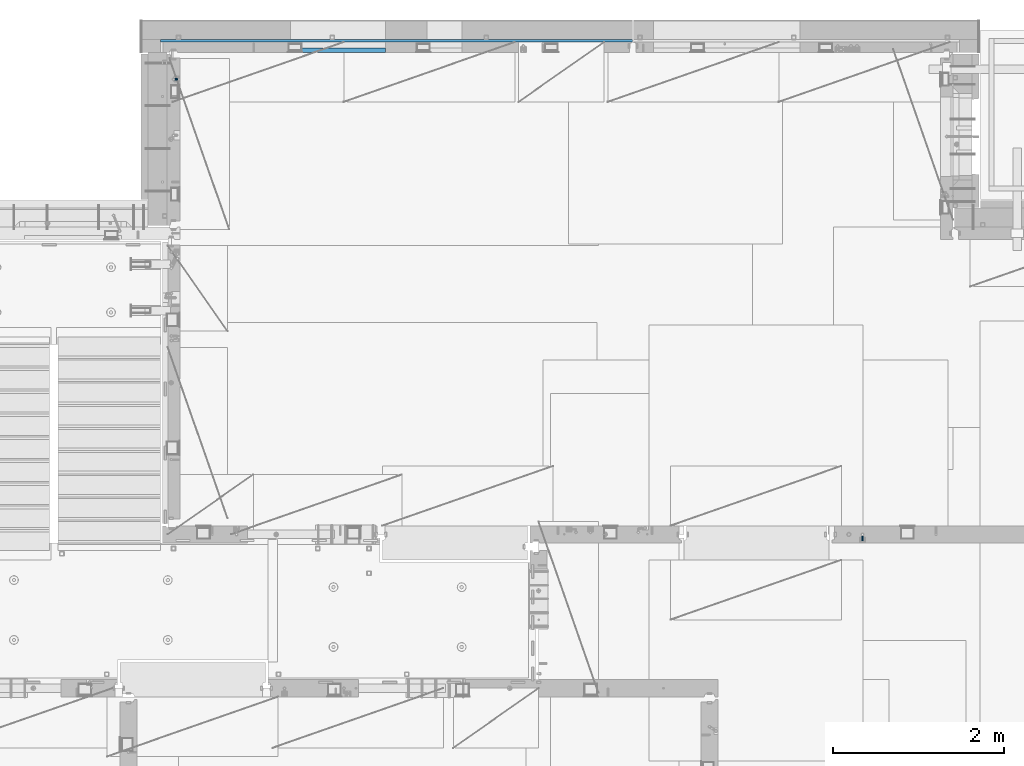
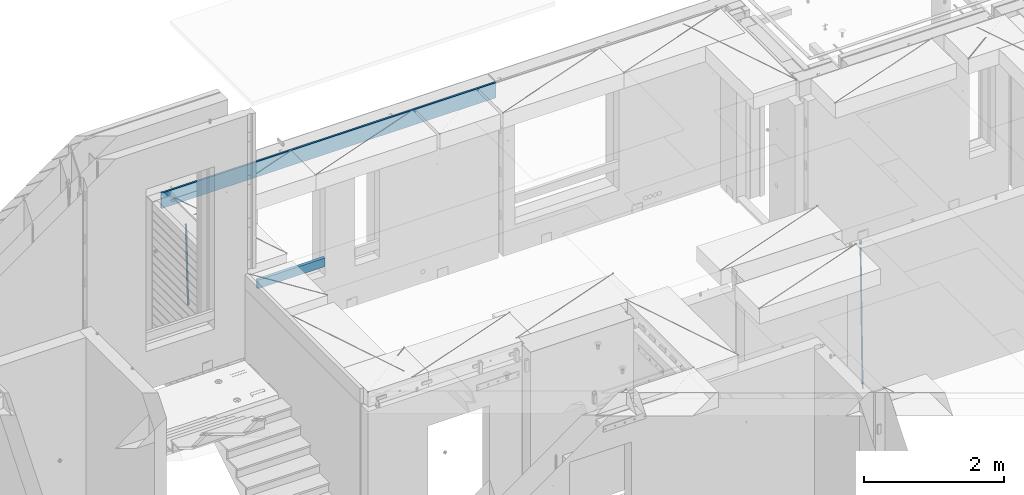
# One storey, part 125 of 352: 4 beams, 3 elements without a shape of their own.
"""IFC2X3 building model written with IfcOpenShell, lengths in millimetres."""

from ifc_helpers import new_model, si_unit, frame, origin_with_axes, place, context, subcontext, project, spatial, faceted_brep, material, type_object, element, aggregate, save


model = new_model("IFC2X3")

# Units and contexts
model_context = context("Model", 3, precision=1e-05, world=origin_with_axes())
body_context = subcontext(model_context, "Body", "Model", "MODEL_VIEW")
ifc_project = project(units=[si_unit("LENGTHUNIT", "METRE", prefix="MILLI"), si_unit("AREAUNIT", "SQUARE_METRE"), si_unit("VOLUMEUNIT", "CUBIC_METRE"), si_unit("MASSUNIT", "GRAM", prefix="KILO"), si_unit("TIMEUNIT", "SECOND"), si_unit("PLANEANGLEUNIT", "RADIAN"), si_unit("SOLIDANGLEUNIT", "STERADIAN"), si_unit("THERMODYNAMICTEMPERATUREUNIT", "DEGREE_CELSIUS"), si_unit("LUMINOUSINTENSITYUNIT", "LUMEN")], contexts=[model_context])

# Site, building, storey
site_placement = place(None, origin_with_axes())
site = spatial("IfcSite", under=ifc_project, at=site_placement, CompositionType="ELEMENT")
building_placement = place(site_placement, origin_with_axes())
building = spatial("IfcBuilding", under=site, at=building_placement, CompositionType="ELEMENT")
storey_placement = place(building_placement, origin_with_axes())
storey = spatial("IfcBuildingStorey", under=building, at=storey_placement, Name="6", CompositionType="ELEMENT", Elevation=0.0)

# Assembly, beam
assembly_1_placement = place(storey_placement, origin_with_axes())
assembly_1 = element("IfcElementAssembly", 1, at=assembly_1_placement, inside=storey, AssemblyPlace="NOTDEFINED", PredefinedType="REINFORCEMENT_UNIT")
ifc_material_1 = material()
beam_type_1 = type_object("IfcBeamType", Name="D20", PredefinedType="NOTDEFINED")
beam_1_placement = place(assembly_1_placement, frame((30400.0000000039, 16915.0002418615, 96990.0), z_axis=(-0.000205762999925498, 0.999642804629538, -0.0267249099901004), x_axis=(4.30000201928125e-08, 0.0267249099948059, 0.999642825806181)))
beam_1 = element("IfcBeam", 2, at=beam_1_placement, type_object=beam_type_1, material=ifc_material_1, Name="JM20", ObjectType="D20", context=body_context, shape_type="Brep", body=[
    faceted_brep([(0.0, -10.0, 0.0), (-4.19531716033816e-08, -7.07106781186667, -7.07106781187031), (60.4266690400545, -7.0710677960451, -7.07106780570757), (60.4266690441291, -9.99999998418934, 6.15546014159918e-09), (0.0, 0.0, -10.0), (60.426669036824, 1.58106558956206e-08, -9.99999999384454), (4.196772351861e-08, 7.07106781186303, -7.07106781186667), (60.4266690363438, 7.07106782768096, -7.07106780570757), (0.0, 10.0, 0.0), (60.4266690388904, 10.0000000158179, 6.15182216279209e-09), (4.196772351861e-08, 7.07106781185939, 7.07106781185939), (60.4266690429649, 7.07106782768096, 7.07106781802577), (0.0, 0.0, 10.0), (60.4266690461809, 1.58179318532348e-08, 10.0000000061555), (-4.19531716033816e-08, -7.07106781187031, 7.07106781185939), (60.4266690466611, -7.07106779605238, 7.07106781802213), (61.0378400410118, -7.07106779588503, -7.07106780564936), (60.991799419251, -9.99999998403655, 6.21366780251265e-09), (61.0569027789461, 1.5985278878361e-08, -9.99999999378269), (61.0378209396877, 7.07106782784831, -7.07106780564936), (60.9917724058905, 10.0000000159635, 6.21366780251265e-09), (60.9457317841297, 7.07106782781193, 7.0710678180767), (60.9266690461809, 1.59488990902901e-08, 10.0000000062028), (60.9457508854539, -7.07106779591413, 7.0710678180767), (61.6489592143771, -7.07106614513759, -7.06310863441468), (61.5568818710308, -9.9999984576425, 0.00735959856683621), (61.6870830769039, 1.71821739058942e-06, -9.99179257185824), (61.6489210170112, 7.07106947854481, -7.06310888312146), (61.556827851804, 10.0000015422847, 0.00735924683976918), (61.4647505084577, 7.07106922979438, 7.07782747982128), (61.4266266459163, 1.36643211590126e-06, 10.0065114172685), (61.464788705809, -7.07106639389531, 7.07782772852806), (176.543135720174, -7.07075579406956, -5.56673531796696), (176.451058376813, -9.99968810657447, 1.50373291501455), (176.581259582701, 0.000312069292704109, -8.49541925541052), (176.543097522794, 7.07137982961285, -5.56673556667374), (176.451004357587, 10.00031189336, 1.50373256329476), (176.35892701424, 7.07137958085514, 8.57420079627263), (176.320803151699, 0.000311717507429421, 11.5028847337162), (176.358965211621, -7.07075604281999, 8.57420104497578), (177.098753836006, -7.07075429323595, -5.55949898843028), (176.98362511232, -9.99968666800123, 1.510669025065), (177.146421932586, 0.000313595905026887, -8.48805862247536), (177.098706077581, 7.07138133041735, -5.55949936166144), (176.983557571715, 10.0003133318824, 1.51066849724157), (176.868428848029, 7.07138095712435, 8.58083651073321), (176.820760751449, 0.000313067976094317, 11.5093961447819), (176.868476606425, -7.07075466652896, 8.58083688396073), (177.654312950661, -7.07075204110879, -5.54863964998367), (177.516135294456, -9.99968450931192, 1.52107783331303), (177.711524267797, 0.000315886711177882, -8.47701274570863), (177.654255632195, 7.07138358250813, -5.54864021007961), (177.516054233929, 10.0003154905207, 1.5210770412159), (177.377876577739, 7.0713830223176, 8.59079452451624), (177.320665260588, 0.000315094497636892, 11.5191676202448), (177.377933896176, -7.07075260129932, 8.59079508461218), (299.499456785634, -7.07025810522464, -3.16697112782276), (299.361279129444, -9.99919057342777, 3.90274635547394), (299.556668102785, 0.000809822595329024, -6.09534422354773), (299.499399467197, 7.07187751838501, -3.1669716879187), (299.361198068917, 10.0008094264049, 3.90274556338045), (299.223020412712, 7.07187695819448, 10.9724630466735), (299.165809095575, 0.000809030381788034, 13.9008361423985), (299.223077731163, -7.07025866542244, 10.9724636067695), (300.03174732349, -7.07025594743027, -3.15656661289177), (299.971788958996, -9.99918809853989, 3.91467979818117), (300.056572611924, 0.000811849109595641, -6.08557274808481), (300.031722507032, 7.07187967631762, -3.15656653768019), (299.971753863239, 10.0008119014747, 3.91467990454839), (299.91179549876, 7.07187975035777, 10.9859263156177), (299.886970210311, 0.000811953817901667, 13.9149324508144), (299.911820315203, -7.0702558733974, 10.9859262404061), (300.564137759997, -7.07025623699155, -3.15794273276697), (300.582413367199, -9.99918843065097, 3.91310145956595), (300.556570941641, 0.000811577163403854, -6.0868651410201), (300.564145451674, 7.07187938674906, -3.15794274158179), (300.582424244858, 10.0008115693345, 3.91310144710224), (300.600699852032, 7.07187937566778, 10.9841456394352), (300.608266670402, 0.000811561512819026, 13.9130680476919), (300.600692160384, -7.07025624805829, 10.98414564825), (2294.16589219622, -7.0713405251372, -8.31099358700158), (2294.1841678034, -10.0002727187966, -1.23994939466866), (2294.15832537785, -0.000272710982244462, -11.2399159952547), (2294.16589988787, 7.07079509858886, -8.31099359582004), (2294.18417868105, 9.99972728118883, -1.23994940713601), (2294.20245428824, 7.07079508752213, 5.83109478519327), (2294.2100211066, -0.00027272663282929, 8.76001719345368), (2294.20244659658, -7.07134053620393, 5.83109479401173), (2294.7782683276, -7.07134085819416, -8.31257645345977), (2294.72126025338, -10.000273010919, -1.24133766827799), (2294.84007459224, -0.000273081772320438, -11.2416781768807), (2294.87047377572, 7.07079471537872, -8.31281477453012), (2294.85165844864, 9.9997269181622, -1.24167470516841), (2294.7946503744, 7.07079476544459, 5.82956408001337), (2294.73284410976, -0.000273010977252852, 8.75866580342336), (2294.7024449263, -7.07134080815013, 5.82980240107645), (2295.39054023061, -7.0793250091956, -8.30442771922026), (2295.25826128852, -10.0072756143927, -1.23419071494573), (2295.52170777075, -0.00916171800054144, -11.2326063125765), (2295.57492774284, 7.06160849139269, -8.30343918807193), (2295.51902460904, 9.99102432676591, -1.23279272078435), (2295.38674566693, 7.06307372157607, 5.83744428349019), (2295.25557812679, -0.0070895696117077, 8.76562287684646), (2295.20235815471, -7.07785977901949, 5.83645575234186), (2317.1947101649, -7.36365585014573, -8.01423575520312), (2317.06243122277, -10.2916064553428, -0.94399875092131), (2317.32587770502, -0.293492558957951, -10.9424143485521), (2317.37909767711, 6.77727765044983, -8.01324722405116), (2317.32319454331, 9.70669348581578, -0.942600756767206), (2317.1909156012, 6.77874288063322, 6.12763624751096), (2317.05974806109, -0.291420410569117, 9.0558148408636), (2317.00652808898, -7.36219061996962, 6.12664771636264), (2317.83015404257, -7.37194216843636, -8.00577862486898), (2317.72252095213, -10.300214160583, -0.935213608652703), (2317.90419832576, -0.301033978277701, -10.9347174723516), (2317.90127966482, 6.77046829039318, -8.00629749759901), (2317.82310777172, 9.70017451494641, -0.935947405505431), (2317.71547468127, 6.77190252279979, 6.13461761071085), (2317.64143039809, -0.29900566735887, 9.06355645819713), (2317.64434905903, -7.37050793602975, 6.13513648344451), (2318.46565174212, -7.3700661537805, -7.99751648408346), (2318.38266643914, -10.2982456018653, -0.926623872735945), (2318.48256818345, -0.299336209594912, -10.9272153854981), (2318.42350634121, 6.77200652527245, -7.99954269419686), (2318.32306384158, 9.70166538090416, -0.929489366557391), (2318.2400785386, 6.77348593281204, 6.14140324480104), (2318.22316209726, -0.297244011366274, 9.07110214621207), (2318.2822239395, -7.36858674623363, 6.1434294549108), (2418.48643733139, -7.07180401323421, -6.70013846199799), (2418.4034520284, -9.99998346132634, 0.370754149349523), (2418.5033537727, -0.00107406904135132, -9.62983736341266), (2418.44429193046, 7.07026866581873, -6.70216467211139), (2418.34384943081, 9.99992752145772, 0.367888655531715), (2418.26086412782, 7.0717480733656, 7.43878126688651), (2418.24394768651, 0.00101812917273492, 10.3684801682975), (2418.30300952874, -7.07032460568735, 7.44080747699627)], [[[0, 1, 2, 3]], [[1, 4, 5, 2]], [[4, 6, 7, 5]], [[6, 8, 9, 7]], [[8, 10, 11, 9]], [[10, 12, 13, 11]], [[12, 14, 15, 13]], [[14, 0, 3, 15]], [[14, 12, 10, 8, 6, 4, 1, 0]], [[3, 2, 16, 17]], [[2, 5, 18, 16]], [[5, 7, 19, 18]], [[7, 9, 20, 19]], [[9, 11, 21, 20]], [[11, 13, 22, 21]], [[13, 15, 23, 22]], [[15, 3, 17, 23]], [[17, 16, 24, 25]], [[16, 18, 26, 24]], [[18, 19, 27, 26]], [[19, 20, 28, 27]], [[20, 21, 29, 28]], [[21, 22, 30, 29]], [[22, 23, 31, 30]], [[23, 17, 25, 31]], [[25, 24, 32, 33]], [[24, 26, 34, 32]], [[26, 27, 35, 34]], [[27, 28, 36, 35]], [[28, 29, 37, 36]], [[29, 30, 38, 37]], [[30, 31, 39, 38]], [[31, 25, 33, 39]], [[33, 32, 40, 41]], [[32, 34, 42, 40]], [[34, 35, 43, 42]], [[35, 36, 44, 43]], [[36, 37, 45, 44]], [[37, 38, 46, 45]], [[38, 39, 47, 46]], [[39, 33, 41, 47]], [[41, 40, 48, 49]], [[40, 42, 50, 48]], [[42, 43, 51, 50]], [[43, 44, 52, 51]], [[44, 45, 53, 52]], [[45, 46, 54, 53]], [[46, 47, 55, 54]], [[47, 41, 49, 55]], [[49, 48, 56, 57]], [[48, 50, 58, 56]], [[50, 51, 59, 58]], [[51, 52, 60, 59]], [[52, 53, 61, 60]], [[53, 54, 62, 61]], [[54, 55, 63, 62]], [[55, 49, 57, 63]], [[57, 56, 64, 65]], [[56, 58, 66, 64]], [[58, 59, 67, 66]], [[59, 60, 68, 67]], [[60, 61, 69, 68]], [[61, 62, 70, 69]], [[62, 63, 71, 70]], [[63, 57, 65, 71]], [[65, 64, 72, 73]], [[64, 66, 74, 72]], [[66, 67, 75, 74]], [[67, 68, 76, 75]], [[68, 69, 77, 76]], [[69, 70, 78, 77]], [[70, 71, 79, 78]], [[71, 65, 73, 79]], [[73, 72, 80, 81]], [[72, 74, 82, 80]], [[74, 75, 83, 82]], [[75, 76, 84, 83]], [[76, 77, 85, 84]], [[77, 78, 86, 85]], [[78, 79, 87, 86]], [[79, 73, 81, 87]], [[81, 80, 88, 89]], [[80, 82, 90, 88]], [[82, 83, 91, 90]], [[83, 84, 92, 91]], [[84, 85, 93, 92]], [[85, 86, 94, 93]], [[86, 87, 95, 94]], [[87, 81, 89, 95]], [[89, 88, 96, 97]], [[88, 90, 98, 96]], [[90, 91, 99, 98]], [[91, 92, 100, 99]], [[92, 93, 101, 100]], [[93, 94, 102, 101]], [[94, 95, 103, 102]], [[95, 89, 97, 103]], [[97, 96, 104, 105]], [[96, 98, 106, 104]], [[98, 99, 107, 106]], [[99, 100, 108, 107]], [[100, 101, 109, 108]], [[101, 102, 110, 109]], [[102, 103, 111, 110]], [[103, 97, 105, 111]], [[105, 104, 112, 113]], [[104, 106, 114, 112]], [[106, 107, 115, 114]], [[107, 108, 116, 115]], [[108, 109, 117, 116]], [[109, 110, 118, 117]], [[110, 111, 119, 118]], [[111, 105, 113, 119]], [[113, 112, 120, 121]], [[112, 114, 122, 120]], [[114, 115, 123, 122]], [[115, 116, 124, 123]], [[116, 117, 125, 124]], [[117, 118, 126, 125]], [[118, 119, 127, 126]], [[119, 113, 121, 127]], [[121, 120, 128, 129]], [[120, 122, 130, 128]], [[122, 123, 131, 130]], [[123, 124, 132, 131]], [[124, 125, 133, 132]], [[125, 126, 134, 133]], [[126, 127, 135, 134]], [[127, 121, 129, 135]], [[130, 131, 132, 133, 134, 135, 129, 128]]]),
])
aggregate(assembly_1, [beam_1])

assembly_2_placement = place(storey_placement, origin_with_axes())
assembly_2 = element("IfcElementAssembly", 3, at=assembly_2_placement, inside=storey, AssemblyPlace="NOTDEFINED", PredefinedType="REINFORCEMENT_UNIT")
beam_type_2 = type_object("IfcBeamType", Name="D25", PredefinedType="NOTDEFINED")
beam_2_placement = place(assembly_2_placement, frame((22375.0000022791, 22307.0000022831, 97990.0), z_axis=(-0.999642804636942, -0.000205726999925762, -0.0267249099902983), x_axis=(-0.0267249099948371, 4.30000201934385e-08, 0.999642825806181)))
beam_2 = element("IfcBeam", 4, at=beam_2_placement, type_object=beam_type_2, material=ifc_material_1, Name="JM25", ObjectType="D25", context=body_context, shape_type="Brep", body=[
    faceted_brep([(-7.41420080885291e-08, -12.5, -3.63797880709171e-12), (-6.42030499875546e-08, -10.8253175473074, -6.25000000000364), (60.4103898235917, -10.8253175318459, -6.2499999938409), (60.4103898269532, -12.4999999845422, 6.16273609921336e-09), (-3.70782800018787e-08, -6.25000000000364, -10.8253175473074), (60.4103898202884, -6.24999998454587, -10.8253175411446), (-1.45519152283669e-11, -3.63797880709171e-12, -12.5), (60.4103898179019, 1.54577719513327e-08, -12.4999999938373), (3.70637280866504e-08, 6.25, -10.8253175473074), (60.410389817087, 6.25000001545777, -10.825317541141), (6.42030499875546e-08, 10.8253175473001, -6.25000000000364), (60.410389818062, 10.8253175627578, -6.24999999383726), (7.41420080885291e-08, 12.4999999999927, 0.0), (60.4103898205503, 12.5000000154541, 6.16273609921336e-09), (6.42176019027829e-08, 10.8253175473001, 6.24999999999636), (60.4103898238973, 10.8253175627651, 6.2500000061591), (3.70928319171071e-08, 6.24999999999636, 10.8253175473037), (60.4103898272151, 6.25000001546141, 10.8253175534664), (1.45519152283669e-11, -3.63797880709171e-12, 12.4999999999964), (60.4103898296162, 1.54541339725256e-08, 12.5000000061591), (-3.7049176171422e-08, -6.25000000000364, 10.8253175473001), (60.4103898304165, -6.24999998454587, 10.8253175534701), (-6.41884980723262e-08, -10.8253175473074, 6.25), (60.4103898294561, -10.8253175318459, 6.25000000616637), (61.0324985728803, -10.8253175316895, -6.24999999377542), (60.991802792938, -12.4999999843931, 6.22458173893392e-09), (61.0622854283865, -6.24999998437852, -10.8253175410755), (61.0731819955545, 1.5628756955266e-08, -12.4999999937718), (61.0622685480339, 6.25000001562512, -10.8253175410791), (61.032469335245, 10.8253175629216, -6.24999999377178), (60.9917690322181, 12.5000000156033, 6.22458173893392e-09), (60.9510732522613, 10.8253175629034, 6.25000000621731), (60.9212863967696, 6.25000001558874, 10.8253175535247), (60.9103898296162, 1.55814632307738e-08, 12.5000000062137), (60.9213032771368, -6.24999998441126, 10.8253175535174), (60.9511024898966, -10.8253175317113, 6.25000000621731), (61.6545545670233, -10.8253158516927, -6.24189838219536), (61.573166454793, -12.499998414296, 0.00757164385504439), (61.7141257553885, -6.24999822394238, -10.8168280205282), (61.7359179680789, 1.80548886419274e-06, -12.491368569139), (61.7140919992817, 6.25000177601396, -10.8168282403167), (61.6544960997562, 10.8253192428383, -6.2418987628771), (61.5730989426083, 12.5000015856094, 0.0075712042817031), (61.4917108303925, 10.8253190230062, 6.25704123032847), (61.4321396420273, 6.25000139525582, 10.8319708686649), (61.4103474293224, 1.36582457344048e-06, 12.5065114172721), (61.4321733981196, -6.24999860470052, 10.8319710884571), (61.4917692976451, -10.8253160715249, 6.25704161101385), (176.524302641745, -10.8250056210964, -4.74584321979273), (176.442914529529, -12.4996881836996, 1.50362680625403), (176.583873830095, -6.24968799334965, -9.3207728581292), (176.605666042786, 0.000312036081595579, -10.9953134067364), (176.583840074018, 6.25031200660669, -9.32077307791769), (176.524244174492, 10.8256294734347, -4.74584360047811), (176.44284701733, 12.5003118162058, 1.50362636668069), (176.361458905099, 10.8256292535989, 7.75309639272746), (176.301887716749, 6.25031162585219, 12.3280260310676), (176.280095504058, 0.000311596420942806, 14.0025665796711), (176.301921472827, -6.24968837410415, 12.3280262508561), (176.361517372367, -10.8250058409321, 7.75309677341284), (177.085397012124, -10.8250041057399, -4.73853556792164), (176.983633547483, -12.4996867233749, 1.51066909103247), (177.159881729676, -6.24968643771717, -9.31327097355097), (177.187129580227, 0.000313606451527448, -10.987740468332), (177.159839524218, 6.25031356221734, -9.31327130338468), (177.085323910098, 10.8256309887511, -4.73853613920801), (176.983549136537, 12.5003132764905, 1.51066843136869), (176.881785671867, 10.8256306588555, 7.7598730903228), (176.80730095433, 6.25031299082912, 12.3346084959521), (176.780053103794, 0.000312946667690994, 14.0090779907332), (176.807343159802, -6.2496870091054, 12.3346088257895), (176.881858773908, -10.8250044356355, 7.7598736616128), (177.646431799818, -10.8250018318176, -4.72756919822132), (177.524295146417, -12.4996845320202, 1.52123723245313), (177.735828462886, -6.24968410334986, -9.30201312475765), (177.768531371941, 0.00031596292683389, -10.9763759912421), (177.735777808921, 6.25031589654827, -9.30201361973741), (177.646344064575, 10.8256332626152, -4.72757005553649), (177.524193838486, 12.5003154677688, 1.52123624250817), (177.402057185071, 10.8256327675663, 7.77004267317898), (177.312660521988, 6.2503150390985, 12.3444865997226), (177.279957612933, 0.00031497282179771, 14.0188494661961), (177.312711175953, -6.24968496079964, 12.3444870946951), (177.402144920314, -10.8250023268702, 7.77004353049415), (299.450416306776, -10.8245081491878, -2.34670520440704), (299.32827965336, -12.4991908493976, 3.9021012262674), (299.539812969844, -6.24919042071997, -6.92114913095065), (299.572515878914, 0.000809645553090377, -8.59551199742418), (299.539762315893, 6.25080957917817, -6.9211496259195), (299.450328571547, 10.8261269452451, -2.34670606172585), (299.328178345429, 12.5008091504023, 3.9021002363188), (299.206041692043, 10.8261264501925, 10.1509066669969), (299.11664502896, 6.25080872172475, 14.7253505935405), (299.083942119891, 0.000808655455330154, 16.3997134600104), (299.116695682911, -6.24919127817338, 14.7253510885093), (299.206129427272, -10.8245086442366, 10.1509075243121), (300.022114107283, -10.8245058320463, -2.33553040816332), (299.97179243555, -12.4991882411778, 3.91467976726199), (300.058946494231, -6.24918831662217, -6.9110017919993), (300.072420388053, 0.000811671710835071, -8.58574052196127), (300.058925469799, 6.25081168339239, -6.91100170781283), (300.022077691901, 10.8261292625939, -2.33553026234586), (299.971750386685, 12.5008117588586, 3.91467993563856), (299.921428714966, 10.8261293497235, 10.1648901110639), (299.884596327989, 6.25081183430666, 14.7403614948998), (299.871122434168, 0.000811845966381952, 16.4151002248582), (299.884617352436, -6.24918816571881, 14.7403614107134), (299.921465130334, -10.8245057449167, 10.1648899652428), (300.593917726728, -10.8245062259339, -2.33749813354007), (300.615424329342, -12.4991886845492, 3.91246486206001), (300.578176108116, -6.24918867429733, -6.91278859651356), (300.572417427509, 0.00081132728519151, -8.58746114217138), (300.578184718717, 6.25081132569903, -6.91278861431056), (300.59393264071, 10.8261288686736, -2.33749816436102), (300.615441550515, 12.5008113154472, 3.91246482646966), (300.636948153115, 10.8261288568356, 10.1624278220661), (300.652689771727, 6.25081130520266, 14.7377182850432), (300.658448452334, 0.000811303612863412, 16.4123908306974), (300.65268116114, -6.24918869479734, 14.7377183028366), (300.636933239148, -10.8245062377719, 10.162427852887), (1293.8225958722, -10.8251904135213, -5.7554570479515), (1293.84410247482, -12.4998728721366, 0.494505947652215), (1293.80685425361, -6.2498728618848, -10.330747510925), (1293.801095573, 0.000127139694086509, -12.0054200565755), (1293.80686286419, 6.25012713810793, -10.3307475287183), (1293.82261078618, 10.8254446810788, -5.75545707877609), (1293.84411969599, 12.5001271278561, 0.49450591205823), (1293.86562629859, 10.8254446692445, 6.7444689076583), (1293.8813679172, 6.25012711760428, 11.3197593706318), (1293.88712659782, 0.00012711602539639, 12.994431916286), (1293.88135930662, -6.24987288238844, 11.3197593884252), (1293.86561138462, -10.8251904253593, 6.7444689384829), (1294.43576264779, -10.8251908359052, -5.75756711474241), (1294.39401066334, -12.4998732509448, 0.492613570157118), (1294.4881651176, -6.24987333120953, -10.3330920792978), (1294.53717687333, 0.000126632643514313, -12.0079531043048), (1294.56966525462, 6.25012661264918, -10.3333725306838), (1294.5769250259, 10.8254441614699, -5.75805287079493), (1294.55701093735, 12.5001266367835, 0.492052667374082), (1294.51525895292, 10.825444221744, 6.74223335227362), (1294.46285648308, 6.25012671704826, 11.3177583168253), (1294.41384472734, 0.000126753191580065, 12.9926193418323), (1294.38135634607, -6.24987322681045, 11.318038768215), (1294.37409657479, -10.8251907756348, 6.74271910832613), (1295.04882664244, -10.8331853159034, -5.74940783883358), (1294.94382667454, -12.5070429642874, 0.499931077909423), (1295.16936177819, -6.25875627512141, -10.3240260249331), (1295.27313478947, -0.00947040924438625, -11.9981582317523), (1295.33233978174, 6.24018118068125, -10.3232220864411), (1295.33111282514, 10.8156093981706, -5.74801537651729), (1295.26978268167, 12.4908319473179, 0.501538954897114), (1295.16478271378, 10.8169742989339, 6.75087787164011), (1295.04424757806, 6.24254525814467, 11.3254960577397), (1294.94047456676, -0.00674060772507801, 12.9996282645552), (1294.88126957447, -6.25639219765071, 11.3246921192476), (1294.88249653111, -10.8318204151437, 6.74948540932019), (1316.80386422646, -11.116875459662, -5.45986978806832), (1316.69886425855, -12.790733108046, 0.789469128674682), (1316.92439936219, -6.54244641887635, -10.0344879741715), (1317.02817237348, -0.293160553006601, -11.7086201809871), (1317.08737736575, 5.95649103692267, -10.0336840356795), (1317.08615040916, 10.5319192544084, -5.45847732575203), (1317.02482026568, 12.2071418035557, 0.791077005658735), (1316.91982029779, 10.5332841551717, 7.0404159223981), (1316.79928516207, 5.9588551143861, 11.6150341085013), (1316.69551215076, -0.290430751483655, 13.2891663153168), (1316.63630715849, -6.54008234141656, 11.6142301700129), (1316.6375341151, -11.1155105589023, 7.03902346008545), (1317.48953548315, -11.1258167532178, -5.45074418126023), (1317.39899812841, -12.7998629970425, 0.798787218573125), (1317.57265877169, -6.55089985429368, -10.0258602820722), (1317.62609517592, -0.300957588759047, -11.7006624193855), (1317.63552645453, 5.94934306058713, -10.0263887130131), (1317.59842550401, 10.5252390823007, -5.4516594505003), (1317.52473349411, 12.2006228327155, 0.79773035668768), (1317.43419613934, 10.5265765888907, 7.0472617565174), (1317.35107285083, 5.95165968996662, 11.6223778573367), (1317.2976364466, -0.29828257556801, 13.2971799946463), (1317.28820516799, -6.54858322491418, 11.6229062882776), (1317.32530611851, -11.1244792466277, 7.04817702575747), (1318.17526469367, -11.1237887330935, -5.44182040245869), (1318.09919107273, -12.797775016028, 0.807903115066438), (1318.22097315147, -6.5489957269856, -10.0174341323618), (1318.22406890181, -0.299208089221793, -11.6929060708244), (1318.18372244084, 5.95094862978294, -10.0192948650074), (1318.11074457024, 10.526749984605, -5.44504328594121), (1318.02468965146, 12.2021136975018, 0.804181649778911), (1317.94861603052, 10.52812741456, 7.05390516730768), (1317.90290757272, 5.95333440845207, 11.6295188972072), (1317.8998118224, -0.296453229308099, 13.3049908356734), (1317.94015828335, -6.54660994831283, 11.6313796298491), (1318.01313615397, -11.1224113031385, 7.0571280507902), (1418.17602640855, -10.8255863639497, -4.14470589025586), (1418.09995278763, -12.4995726468842, 2.10501762727654), (1418.22173486637, -6.25079335783812, -8.72031962014808), (1418.2248306167, -0.00100572007431765, -10.3957915586216), (1418.18448415573, 6.24915099893042, -8.72218035279366), (1418.11150628512, 10.8249523537488, -4.14792877373111), (1418.02545136634, 12.500316066642, 2.10129616199265), (1417.94937774542, 10.8263297837075, 8.35101967951414), (1417.90366928761, 6.2515367775959, 12.9266334094173), (1417.90057353729, 0.00174913983573788, 14.6021053478798), (1417.94091999825, -6.248407579169, 12.9284941420592), (1418.01389786886, -10.824208933991, 8.35424256299666)], [[[0, 1, 2, 3]], [[1, 4, 5, 2]], [[4, 6, 7, 5]], [[6, 8, 9, 7]], [[8, 10, 11, 9]], [[10, 12, 13, 11]], [[12, 14, 15, 13]], [[14, 16, 17, 15]], [[16, 18, 19, 17]], [[18, 20, 21, 19]], [[20, 22, 23, 21]], [[22, 0, 3, 23]], [[22, 20, 18, 16, 14, 12, 10, 8, 6, 4, 1, 0]], [[3, 2, 24, 25]], [[2, 5, 26, 24]], [[5, 7, 27, 26]], [[7, 9, 28, 27]], [[9, 11, 29, 28]], [[11, 13, 30, 29]], [[13, 15, 31, 30]], [[15, 17, 32, 31]], [[17, 19, 33, 32]], [[19, 21, 34, 33]], [[21, 23, 35, 34]], [[23, 3, 25, 35]], [[25, 24, 36, 37]], [[24, 26, 38, 36]], [[26, 27, 39, 38]], [[27, 28, 40, 39]], [[28, 29, 41, 40]], [[29, 30, 42, 41]], [[30, 31, 43, 42]], [[31, 32, 44, 43]], [[32, 33, 45, 44]], [[33, 34, 46, 45]], [[34, 35, 47, 46]], [[35, 25, 37, 47]], [[37, 36, 48, 49]], [[36, 38, 50, 48]], [[38, 39, 51, 50]], [[39, 40, 52, 51]], [[40, 41, 53, 52]], [[41, 42, 54, 53]], [[42, 43, 55, 54]], [[43, 44, 56, 55]], [[44, 45, 57, 56]], [[45, 46, 58, 57]], [[46, 47, 59, 58]], [[47, 37, 49, 59]], [[49, 48, 60, 61]], [[48, 50, 62, 60]], [[50, 51, 63, 62]], [[51, 52, 64, 63]], [[52, 53, 65, 64]], [[53, 54, 66, 65]], [[54, 55, 67, 66]], [[55, 56, 68, 67]], [[56, 57, 69, 68]], [[57, 58, 70, 69]], [[58, 59, 71, 70]], [[59, 49, 61, 71]], [[61, 60, 72, 73]], [[60, 62, 74, 72]], [[62, 63, 75, 74]], [[63, 64, 76, 75]], [[64, 65, 77, 76]], [[65, 66, 78, 77]], [[66, 67, 79, 78]], [[67, 68, 80, 79]], [[68, 69, 81, 80]], [[69, 70, 82, 81]], [[70, 71, 83, 82]], [[71, 61, 73, 83]], [[73, 72, 84, 85]], [[72, 74, 86, 84]], [[74, 75, 87, 86]], [[75, 76, 88, 87]], [[76, 77, 89, 88]], [[77, 78, 90, 89]], [[78, 79, 91, 90]], [[79, 80, 92, 91]], [[80, 81, 93, 92]], [[81, 82, 94, 93]], [[82, 83, 95, 94]], [[83, 73, 85, 95]], [[85, 84, 96, 97]], [[84, 86, 98, 96]], [[86, 87, 99, 98]], [[87, 88, 100, 99]], [[88, 89, 101, 100]], [[89, 90, 102, 101]], [[90, 91, 103, 102]], [[91, 92, 104, 103]], [[92, 93, 105, 104]], [[93, 94, 106, 105]], [[94, 95, 107, 106]], [[95, 85, 97, 107]], [[97, 96, 108, 109]], [[96, 98, 110, 108]], [[98, 99, 111, 110]], [[99, 100, 112, 111]], [[100, 101, 113, 112]], [[101, 102, 114, 113]], [[102, 103, 115, 114]], [[103, 104, 116, 115]], [[104, 105, 117, 116]], [[105, 106, 118, 117]], [[106, 107, 119, 118]], [[107, 97, 109, 119]], [[109, 108, 120, 121]], [[108, 110, 122, 120]], [[110, 111, 123, 122]], [[111, 112, 124, 123]], [[112, 113, 125, 124]], [[113, 114, 126, 125]], [[114, 115, 127, 126]], [[115, 116, 128, 127]], [[116, 117, 129, 128]], [[117, 118, 130, 129]], [[118, 119, 131, 130]], [[119, 109, 121, 131]], [[121, 120, 132, 133]], [[120, 122, 134, 132]], [[122, 123, 135, 134]], [[123, 124, 136, 135]], [[124, 125, 137, 136]], [[125, 126, 138, 137]], [[126, 127, 139, 138]], [[127, 128, 140, 139]], [[128, 129, 141, 140]], [[129, 130, 142, 141]], [[130, 131, 143, 142]], [[131, 121, 133, 143]], [[133, 132, 144, 145]], [[132, 134, 146, 144]], [[134, 135, 147, 146]], [[135, 136, 148, 147]], [[136, 137, 149, 148]], [[137, 138, 150, 149]], [[138, 139, 151, 150]], [[139, 140, 152, 151]], [[140, 141, 153, 152]], [[141, 142, 154, 153]], [[142, 143, 155, 154]], [[143, 133, 145, 155]], [[145, 144, 156, 157]], [[144, 146, 158, 156]], [[146, 147, 159, 158]], [[147, 148, 160, 159]], [[148, 149, 161, 160]], [[149, 150, 162, 161]], [[150, 151, 163, 162]], [[151, 152, 164, 163]], [[152, 153, 165, 164]], [[153, 154, 166, 165]], [[154, 155, 167, 166]], [[155, 145, 157, 167]], [[157, 156, 168, 169]], [[156, 158, 170, 168]], [[158, 159, 171, 170]], [[159, 160, 172, 171]], [[160, 161, 173, 172]], [[161, 162, 174, 173]], [[162, 163, 175, 174]], [[163, 164, 176, 175]], [[164, 165, 177, 176]], [[165, 166, 178, 177]], [[166, 167, 179, 178]], [[167, 157, 169, 179]], [[169, 168, 180, 181]], [[168, 170, 182, 180]], [[170, 171, 183, 182]], [[171, 172, 184, 183]], [[172, 173, 185, 184]], [[173, 174, 186, 185]], [[174, 175, 187, 186]], [[175, 176, 188, 187]], [[176, 177, 189, 188]], [[177, 178, 190, 189]], [[178, 179, 191, 190]], [[179, 169, 181, 191]], [[181, 180, 192, 193]], [[180, 182, 194, 192]], [[182, 183, 195, 194]], [[183, 184, 196, 195]], [[184, 185, 197, 196]], [[185, 186, 198, 197]], [[186, 187, 199, 198]], [[187, 188, 200, 199]], [[188, 189, 201, 200]], [[189, 190, 202, 201]], [[190, 191, 203, 202]], [[191, 181, 193, 203]], [[194, 195, 196, 197, 198, 199, 200, 201, 202, 203, 193, 192]]]),
])
aggregate(assembly_2, [beam_2])

# Assembly, beams
assembly_3_placement = place(storey_placement, origin_with_axes())
assembly_3 = element("IfcElementAssembly", 5, at=assembly_3_placement, inside=storey, AssemblyPlace="NOTDEFINED", PredefinedType="REINFORCEMENT_UNIT")
ifc_material_2 = material(Name="TIMBER/T24")
beam_type_3 = type_object("IfcBeamType", PredefinedType="NOTDEFINED")
beam_3_placement = place(assembly_3_placement, frame((24815.0002989914, 22644.9998418812, 97685.0), z_axis=(0.0, 0.0, 1.0), x_axis=(-1.0, 3.00000001838171e-08, 0.0)))
beam_3 = element("IfcBeam", 6, at=beam_3_placement, type_object=beam_type_3, material=ifc_material_2, context=body_context, shape_type="Brep", body=[
    faceted_brep([(-3.63797880709171e-12, 24.9999999999964, -75.0), (-3.63797880709171e-12, 24.9999999999964, 75.0), (1110.0, 24.9999999999964, 75.0), (1110.0, 24.9999999999964, -75.0), (0.0, -25.0000000000073, 75.0), (1110.0, -25.0000000000073, 75.0), (0.0, -25.0000000000073, -75.0), (1110.0, -25.0000000000073, -75.0)], [[[0, 1, 2, 3]], [[1, 4, 5, 2]], [[4, 6, 7, 5]], [[6, 0, 3, 7]], [[5, 7, 3, 2]], [[6, 4, 1, 0]]]),
])
ifc_material_3 = material(Name="CONCRETE/C25/30")
beam_type_4 = type_object("IfcBeamType", Name="270X30", PredefinedType="NOTDEFINED")
beam_4_placement = place(assembly_3_placement, frame((27705.0, 22755.0, 99605.0), z_axis=(0.0, 0.0, 1.0), x_axis=(-1.0, 3.00000001838171e-08, 0.0)))
beam_4 = element("IfcBeam", 7, at=beam_4_placement, type_object=beam_type_4, material=ifc_material_3, ObjectType="270X30", context=body_context, shape_type="Brep", body=[
    faceted_brep([(0.0, 15.0, -135.0), (0.0, 15.0, 135.0), (5520.00000000003, 15.0, 135.0), (5520.00000000003, 15.0, -135.0), (0.0, -15.0, 135.0), (5520.00000000003, -15.0, 135.0), (0.0, -15.0, -135.0), (5520.00000000003, -15.0, -135.0)], [[[0, 1, 2, 3]], [[1, 4, 5, 2]], [[4, 6, 7, 5]], [[6, 0, 3, 7]], [[5, 7, 3, 2]], [[6, 4, 1, 0]]]),
])
aggregate(assembly_3, [beam_3, beam_4])

save(model, "model.ifc")
